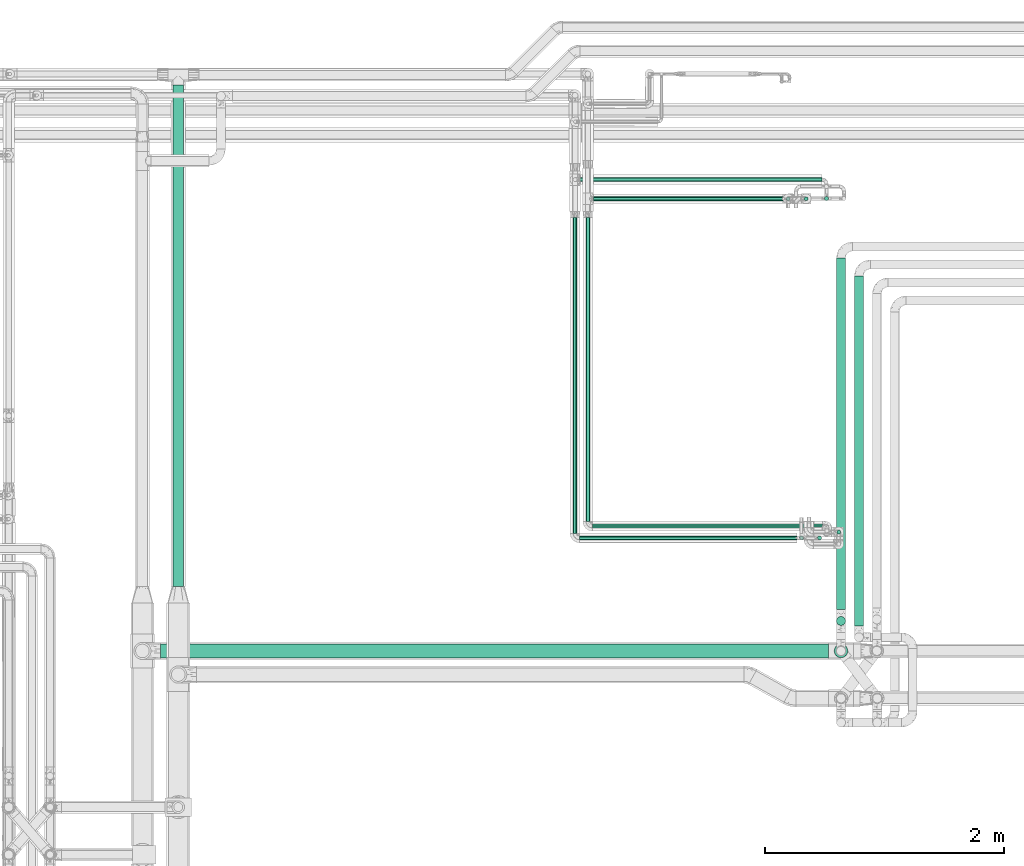
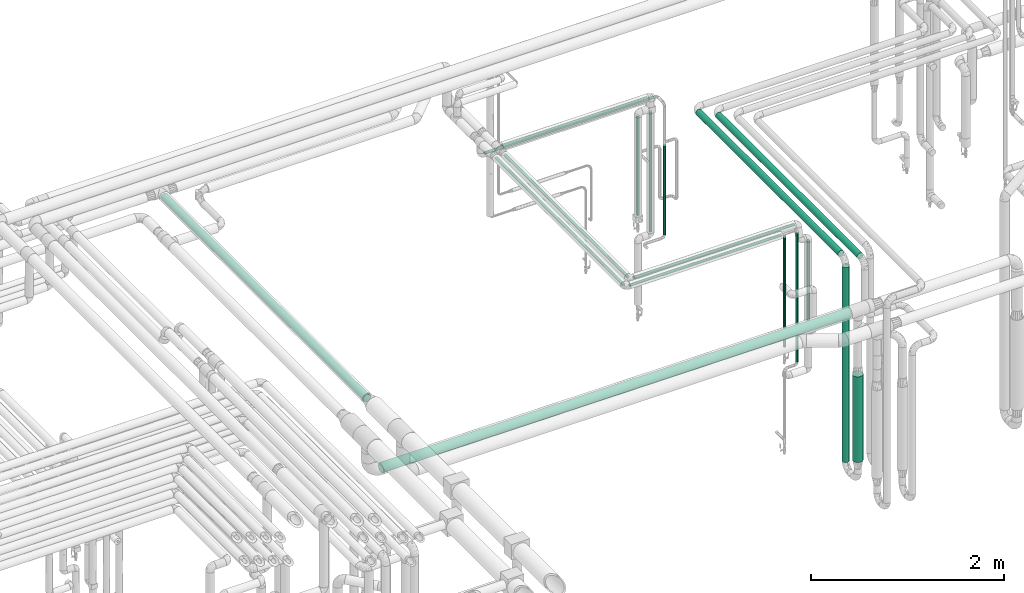
# One storey, part 535 of 827: 18 flow segments.
"""IFC2X3 building model written with IfcOpenShell, lengths in millimetres."""

import ifcopenshell
import ifcopenshell.guid

model = None  # the IFC model being written
_history = None  # IfcOwnerHistory: only IFC2X3 demands one
_inside = {}  # id of a spatial element -> (the spatial element, [elements in it])
_under = {}  # id of a project, library or spatial element -> (it, [spatial elements below it])
_declared = {}  # id of a project -> (the project, [libraries it declares])
_typed = {}  # id of a type object -> (the type object, [elements of that type])
_made_of = {}  # id of a material, layer set ... -> (it, [elements and type objects made of it])


def new_model(schema):
    """Start an empty IFC model of exactly this schema.

    Asked for "IFC4X3", IfcOpenShell would pick the latest addendum, in which some entities
    have other attributes; the version numbers below select the first issue.
    IFC2X3 requires an IfcOwnerHistory on every rooted entity: one is made here for all.
    """
    global model, _history
    if schema == "IFC4X3":
        model = ifcopenshell.file(schema_version=(4, 3, 0, 0))
    else:
        model = ifcopenshell.file(schema=schema)
    _inside.clear()
    _under.clear()
    _declared.clear()
    _typed.clear()
    _made_of.clear()
    _history = None
    if model.schema == "IFC2X3":
        org = make("IfcOrganization", Name="unknown")
        user = make(
            "IfcPersonAndOrganization",
            ThePerson=make("IfcPerson", FamilyName="unknown"),
            TheOrganization=org,
        )
        app = make(
            "IfcApplication",
            ApplicationDeveloper=org,
            Version="unknown",
            ApplicationFullName="unknown",
            ApplicationIdentifier="unknown",
        )
        _history = make(
            "IfcOwnerHistory",
            OwningUser=user,
            OwningApplication=app,
            ChangeAction="ADDED",
            CreationDate=0,
        )
    return model


def make(cls, **values):
    """One entity of the class cls with the attributes given. An attribute that is None is left unset."""
    return model.create_entity(
        cls, **{name: value for name, value in values.items() if value is not None}
    )


def entity(cls, *values):
    """Any entity or typed value of the class cls, its attributes in the order of the schema. None: left unset."""
    e = model.create_entity(cls)
    for i, value in enumerate(values):
        if value is not None:
            e[i] = value
    return e


def rooted(cls, **values):
    """An entity with a GlobalId (a new one), such as an element, a storey or a relation."""
    return make(cls, GlobalId=ifcopenshell.guid.new(), OwnerHistory=_history, **values)


def si_unit(unit_type, name, prefix=None):
    """IfcSIUnit, for example si_unit("LENGTHUNIT", "METRE", prefix="MILLI")."""
    return make("IfcSIUnit", UnitType=unit_type, Prefix=prefix, Name=name)


def converted_unit(unit_type, name, factor, base, dimensions=None, offset=None):
    """IfcConversionBasedUnit, such as the inch: factor (a typed value) times the base unit."""
    return make(
        "IfcConversionBasedUnit"
        if offset is None
        else "IfcConversionBasedUnitWithOffset",
        ConversionOffset=offset,
        Dimensions=None
        if dimensions is None
        else entity("IfcDimensionalExponents", *dimensions),
        UnitType=unit_type,
        Name=name,
        ConversionFactor=make(
            "IfcMeasureWithUnit", ValueComponent=factor, UnitComponent=base
        ),
    )


def derived_unit(unit_type, elements):
    """IfcDerivedUnit: a product of units, each with its exponent."""
    return make(
        "IfcDerivedUnit",
        Elements=[
            make("IfcDerivedUnitElement", Unit=unit, Exponent=power)
            for unit, power in elements
        ],
        UnitType=unit_type,
    )


def assignment(units):
    """IfcUnitAssignment: the units of a project."""
    return None if units is None else make("IfcUnitAssignment", Units=units)


def point(xyz):
    """IfcCartesianPoint."""
    return None if xyz is None else make("IfcCartesianPoint", Coordinates=xyz)


def direction(xyz):
    """IfcDirection."""
    return None if xyz is None else make("IfcDirection", DirectionRatios=xyz)


def frame(location, z_axis=None, x_axis=None):
    """IfcAxis2Placement3D, a coordinate frame: its origin and axes. An axis left out is left unset."""
    return make(
        "IfcAxis2Placement3D",
        Location=point(location),
        Axis=direction(z_axis),
        RefDirection=direction(x_axis),
    )


def frame_2d(location, x_axis=None):
    """IfcAxis2Placement2D, a coordinate frame in the plane: its origin and x axis."""
    return make(
        "IfcAxis2Placement2D", Location=point(location), RefDirection=direction(x_axis)
    )


def origin():
    """The frame at (0, 0, 0) with its axes left unset."""
    return frame((0.0, 0.0, 0.0))


def origin_2d_with_axis():
    """The frame at (0, 0) in the plane with the x axis (1, 0) written out."""
    return frame_2d((0.0, 0.0), x_axis=(1.0, 0.0))


def place(relative_to, where):
    """IfcLocalPlacement: puts the frame where relative to a parent placement (None: the world)."""
    return make(
        "IfcLocalPlacement", PlacementRelTo=relative_to, RelativePlacement=where
    )


def context(
    kind, dimensions, precision=None, world=None, true_north=None, identifier=None
):
    """IfcGeometricRepresentationContext, for example the 3D "Model" context."""
    return make(
        "IfcGeometricRepresentationContext",
        ContextIdentifier=identifier,
        ContextType=kind,
        CoordinateSpaceDimension=dimensions,
        Precision=precision,
        WorldCoordinateSystem=world,
        TrueNorth=true_north,
    )


def subcontext(parent, identifier, kind, view, scale=None):
    """IfcGeometricRepresentationSubContext, for example "Body" below "Model"."""
    return make(
        "IfcGeometricRepresentationSubContext",
        ContextIdentifier=identifier,
        ContextType=kind,
        ParentContext=parent,
        TargetScale=scale,
        TargetView=view,
    )


def project(units=None, contexts=None):
    """IfcProject with its units and contexts."""
    return rooted(
        "IfcProject",
        Name="project",
        RepresentationContexts=contexts,
        UnitsInContext=assignment(units),
    )


def spatial(cls, under=None, at=None, **own):
    """A site, building, storey or space (cls), placed at a placement, below another one or the project."""
    s = rooted(cls, ObjectPlacement=at, **own)
    if under is not None:
        _under.setdefault(under.id(), (under, []))[1].append(s)
    return s


def profile(cls, at=None, kind="AREA", **sizes):
    """A parametric profile (cls). Its sizes go by their IFC names, for example OverallWidth=200.0."""
    return make(cls, ProfileType=kind, Position=at, **sizes)


def circle(**sizes):
    """IfcCircleProfileDef."""
    return profile("IfcCircleProfileDef", **sizes)


def extrude(swept, where, along, depth):
    """IfcExtrudedAreaSolid: the profile swept, set in the frame where, extruded along a direction by depth."""
    return make(
        "IfcExtrudedAreaSolid",
        SweptArea=swept,
        Position=where,
        ExtrudedDirection=direction(along),
        Depth=depth,
    )


def shape(context_of_items, identifier, shape_type, items):
    """IfcShapeRepresentation: the items that make up one representation, for example the "Body"."""
    return make(
        "IfcShapeRepresentation",
        ContextOfItems=context_of_items,
        RepresentationIdentifier=identifier,
        RepresentationType=shape_type,
        Items=items,
    )


def made_of(thing, what):
    """Note that an element or type object is made of a material, layer set ...; save() writes the relation."""
    if what is not None:
        _made_of.setdefault(what.id(), (what, []))[1].append(thing)
    return thing


def type_object(cls, material=None, **own):
    """A type object (cls), such as IfcWallType, which elements share."""
    return made_of(rooted(cls, **own), material)


def element(
    cls,
    number,
    at=None,
    inside=None,
    cuts=None,
    type_object=None,
    material=None,
    context=None,
    identifier="Body",
    shape_type=None,
    held_by="IfcProductDefinitionShape",
    body=None,
    shapes=None,
    **own,
):
    """One element of the class cls, such as IfcWall. Its Tag is "e" and its number.

    at: its placement. inside: the storey or other place that contains it. cuts: it is an
    opening in that element (IfcRelVoidsElement). A single representation is given by context,
    identifier, shape_type and body (its items); several are given by shapes. held_by: the class
    of the entity that holds the representations. save() writes the other relations.
    """
    e = rooted(cls, Tag="e%d" % number, ObjectPlacement=at, **own)
    if body is not None:
        shapes = [shape(context, identifier, shape_type, body)]
    if shapes is not None:
        e.Representation = make(held_by, Representations=shapes)
    if inside is not None:
        _inside.setdefault(inside.id(), (inside, []))[1].append(e)
    if cuts is not None:
        rooted(
            "IfcRelVoidsElement", RelatingBuildingElement=cuts, RelatedOpeningElement=e
        )
    if type_object is not None:
        _typed.setdefault(type_object.id(), (type_object, []))[1].append(e)
    return made_of(e, material)


def aggregate(whole, parts):
    """IfcRelAggregates: a whole, such as a stair, and the parts it consists of."""
    return rooted("IfcRelAggregates", RelatingObject=whole, RelatedObjects=parts)


def save(model, path):
    """Write the relations noted so far, then the file.

    IfcRelAggregates (storeys below a building ...), IfcRelContainedInSpatialStructure (elements
    in a storey), IfcRelDefinesByType, IfcRelAssociatesMaterial and IfcRelDeclares: one each for
    every whole, place, type object, material and project.
    """
    for whole, parts in _under.values():
        aggregate(whole, parts)
    for where, things in _inside.values():
        rooted(
            "IfcRelContainedInSpatialStructure",
            RelatedElements=things,
            RelatingStructure=where,
        )
    for kind, things in _typed.values():
        rooted("IfcRelDefinesByType", RelatedObjects=things, RelatingType=kind)
    for what, things in _made_of.values():
        rooted("IfcRelAssociatesMaterial", RelatedObjects=things, RelatingMaterial=what)
    for by, libraries in _declared.values():
        rooted("IfcRelDeclares", RelatingContext=by, RelatedDefinitions=libraries)
    model.write(path)


model = new_model("IFC2X3")

# Units and contexts
model_context = context("Model", 3, precision=0.01, world=origin(), true_north=direction((6.12303176911189e-17, 1.0)))
body_context = subcontext(model_context, "Body", "Model", "MODEL_VIEW")
ifc_project = project(units=[si_unit("LENGTHUNIT", "METRE", prefix="MILLI"), si_unit("AREAUNIT", "SQUARE_METRE"), si_unit("VOLUMEUNIT", "CUBIC_METRE"), converted_unit("PLANEANGLEUNIT", "DEGREE", entity("IfcRatioMeasure", 0.0174532925199433), si_unit("PLANEANGLEUNIT", "RADIAN"), dimensions=[0, 0, 0, 0, 0, 0, 0]), si_unit("MASSUNIT", "GRAM", prefix="KILO"), derived_unit("MASSDENSITYUNIT", [(si_unit("MASSUNIT", "GRAM", prefix="KILO"), 1), (si_unit("LENGTHUNIT", "METRE"), -3)]), derived_unit("MOMENTOFINERTIAUNIT", [(si_unit("LENGTHUNIT", "METRE"), 4)]), si_unit("TIMEUNIT", "SECOND"), si_unit("FREQUENCYUNIT", "HERTZ"), si_unit("THERMODYNAMICTEMPERATUREUNIT", "DEGREE_CELSIUS"), derived_unit("THERMALTRANSMITTANCEUNIT", [(si_unit("MASSUNIT", "GRAM", prefix="KILO"), 1), (si_unit("THERMODYNAMICTEMPERATUREUNIT", "KELVIN"), -1), (si_unit("TIMEUNIT", "SECOND"), -3)]), derived_unit("VOLUMETRICFLOWRATEUNIT", [(si_unit("LENGTHUNIT", "METRE"), 3), (si_unit("TIMEUNIT", "SECOND"), -1)]), derived_unit("MASSFLOWRATEUNIT", [(si_unit("MASSUNIT", "GRAM", prefix="KILO"), 1), (si_unit("TIMEUNIT", "SECOND"), -1)]), derived_unit("ROTATIONALFREQUENCYUNIT", [(si_unit("TIMEUNIT", "SECOND"), -1)]), si_unit("ELECTRICCURRENTUNIT", "AMPERE"), si_unit("ELECTRICVOLTAGEUNIT", "VOLT"), si_unit("POWERUNIT", "WATT"), si_unit("FORCEUNIT", "NEWTON", prefix="KILO"), si_unit("ILLUMINANCEUNIT", "LUX"), si_unit("LUMINOUSFLUXUNIT", "LUMEN"), si_unit("LUMINOUSINTENSITYUNIT", "CANDELA"), derived_unit("USERDEFINED", [(si_unit("MASSUNIT", "GRAM", prefix="KILO"), -1), (si_unit("LENGTHUNIT", "METRE"), -2), (si_unit("TIMEUNIT", "SECOND"), 3), (si_unit("LUMINOUSFLUXUNIT", "LUMEN"), 1)]), derived_unit("LINEARVELOCITYUNIT", [(si_unit("LENGTHUNIT", "METRE"), 1), (si_unit("TIMEUNIT", "SECOND"), -1)]), si_unit("PRESSUREUNIT", "PASCAL"), derived_unit("USERDEFINED", [(si_unit("LENGTHUNIT", "METRE"), -2), (si_unit("MASSUNIT", "GRAM", prefix="KILO"), 1), (si_unit("TIMEUNIT", "SECOND"), -2)]), derived_unit("LINEARFORCEUNIT", [(si_unit("MASSUNIT", "GRAM", prefix="KILO"), 1), (si_unit("LENGTHUNIT", "METRE"), 1), (si_unit("TIMEUNIT", "SECOND"), -2), (si_unit("LENGTHUNIT", "METRE"), -1)]), derived_unit("PLANARFORCEUNIT", [(si_unit("MASSUNIT", "GRAM", prefix="KILO"), 1), (si_unit("LENGTHUNIT", "METRE"), 1), (si_unit("TIMEUNIT", "SECOND"), -2), (si_unit("LENGTHUNIT", "METRE"), -2)])], contexts=[model_context])

# Site, building, storey
site_placement = place(None, origin())
site = spatial("IfcSite", under=ifc_project, at=site_placement, CompositionType="ELEMENT")
building_placement = place(site_placement, origin())
building = spatial("IfcBuilding", under=site, at=building_placement, CompositionType="ELEMENT")
storey_placement = place(building_placement, frame((0.0, 0.0, 28200.0)))
storey = spatial("IfcBuildingStorey", under=building, at=storey_placement, Name="08", CompositionType="ELEMENT", Elevation=28200.0)

# Flow segments
pipe_segment_type_1 = type_object("IfcPipeSegmentType", PredefinedType="NOTDEFINED")
flow_segment_1_placement = place(storey_placement, frame((38002.2, 14827.72, 2953.9)))
element("IfcFlowSegment", 1, at=flow_segment_1_placement, inside=storey, type_object=pipe_segment_type_1, context=body_context, shape_type="SweptSolid", body=[
    extrude(circle(Radius=44.5, at=origin_2d_with_axis()), frame((46.1, 0.0, 46.1), z_axis=(0.0, 1.0, 0.0), x_axis=(-1.0, 0.0, 0.0)), (0.0, 0.0, 1.0), 4193.99999999999),
])
pipe_segment_type_2 = type_object("IfcPipeSegmentType", PredefinedType="NOTDEFINED")
flow_segment_2_placement = place(storey_placement, frame((37900.3, 14228.02, 2441.4)))
element("IfcFlowSegment", 2, at=flow_segment_2_placement, inside=storey, type_object=pipe_segment_type_2, context=body_context, shape_type="SweptSolid", body=[
    extrude(circle(Radius=57.0, at=origin_2d_with_axis()), frame((0.0, 58.6, 58.6), z_axis=(1.0, 0.0, 0.0), x_axis=(0.0, 1.0, 0.0)), (0.0, 0.0, 1.0), 5589.73431158422),
])
flow_segment_3_placement = place(storey_placement, frame((43555.69, 14498.73, 445.0)))
element("IfcFlowSegment", 3, at=flow_segment_3_placement, inside=storey, type_object=pipe_segment_type_2, context=body_context, shape_type="SweptSolid", body=[
    extrude(circle(Radius=37.75, at=origin_2d_with_axis()), frame((39.35, 39.35, 0.0), z_axis=(0.0, 0.0, 1.0), x_axis=(-1.0, 0.0, 0.0)), (0.0, 0.0, 1.0), 2460.0),
])
flow_segment_4_placement = place(storey_placement, frame((43705.69, 14496.04, 2960.65)))
element("IfcFlowSegment", 4, at=flow_segment_4_placement, inside=storey, type_object=pipe_segment_type_2, context=body_context, shape_type="SweptSolid", body=[
    extrude(circle(Radius=37.75, at=origin_2d_with_axis()), frame((39.35, 0.0, 39.35), z_axis=(0.0, 1.0, 0.0), x_axis=(1.0, 0.0, 0.0)), (0.0, 0.0, 1.0), 2930.00000000002),
])
flow_segment_5_placement = place(storey_placement, frame((43555.69, 14633.08, 2960.65)))
element("IfcFlowSegment", 5, at=flow_segment_5_placement, inside=storey, type_object=pipe_segment_type_2, context=body_context, shape_type="SweptSolid", body=[
    extrude(circle(Radius=37.75, at=origin_2d_with_axis()), frame((39.35, 0.0, 39.35), z_axis=(0.0, 1.0, 0.0), x_axis=(1.0, 0.0, 0.0)), (0.0, 0.0, 1.0), 2943.15846247455),
])
flow_segment_6_placement = place(storey_placement, frame((41524.22, 18052.89, 2981.65)))
element("IfcFlowSegment", 6, at=flow_segment_6_placement, inside=storey, type_object=pipe_segment_type_2, context=body_context, shape_type="SweptSolid", body=[
    extrude(circle(Radius=16.75, at=origin_2d_with_axis()), frame((0.0, 18.35, 18.35), z_axis=(1.0, 0.0, 0.0), x_axis=(0.0, 1.0, 0.0)), (0.0, 0.0, 1.0), 1740.87191154267),
])
flow_segment_7_placement = place(storey_placement, frame((43284.74, 18052.89, 1297.88)))
element("IfcFlowSegment", 7, at=flow_segment_7_placement, inside=storey, type_object=pipe_segment_type_2, context=body_context, shape_type="SweptSolid", body=[
    extrude(circle(Radius=16.75, at=origin_2d_with_axis()), frame((18.35, 18.35, 0.0)), (0.0, 0.0, 1.0), 1514.12352106977),
])
flow_segment_8_placement = place(storey_placement, frame((43454.74, 18055.09, 1199.75)))
element("IfcFlowSegment", 8, at=flow_segment_8_placement, inside=storey, type_object=pipe_segment_type_2, context=body_context, shape_type="SweptSolid", body=[
    extrude(circle(Radius=16.75, at=origin_2d_with_axis()), frame((18.35, 18.35, 0.0)), (0.0, 0.0, 1.0), 1126.13619417941),
])
flow_segment_9_placement = place(storey_placement, frame((41407.37, 18212.59, 2831.65)))
element("IfcFlowSegment", 9, at=flow_segment_9_placement, inside=storey, type_object=pipe_segment_type_2, context=body_context, shape_type="SweptSolid", body=[
    extrude(circle(Radius=16.75, at=origin_2d_with_axis()), frame((0.0, 18.35, 18.35), z_axis=(1.0, 0.0, 0.0), x_axis=(0.0, -1.0, 0.0)), (0.0, 0.0, 1.0), 2027.71557427449),
])
flow_segment_10_placement = place(storey_placement, frame((43134.74, 18052.59, 1557.25)))
element("IfcFlowSegment", 10, at=flow_segment_10_placement, inside=storey, type_object=pipe_segment_type_2, context=body_context, shape_type="SweptSolid", body=[
    extrude(circle(Radius=16.75, at=origin_2d_with_axis()), frame((18.35, 18.35, 0.0)), (0.0, 0.0, 1.0), 1254.75207132545),
])
flow_segment_11_placement = place(storey_placement, frame((41457.87, 15370.31, 2981.65)))
element("IfcFlowSegment", 11, at=flow_segment_11_placement, inside=storey, type_object=pipe_segment_type_2, context=body_context, shape_type="SweptSolid", body=[
    extrude(circle(Radius=16.75, at=origin_2d_with_axis()), frame((18.35, 0.0, 18.35), z_axis=(0.0, 1.0, 0.0), x_axis=(-1.0, 0.0, 0.0)), (0.0, 0.0, 1.0), 2542.92701824606),
])
flow_segment_12_placement = place(storey_placement, frame((41514.22, 15313.97, 2981.65)))
element("IfcFlowSegment", 12, at=flow_segment_12_placement, inside=storey, type_object=pipe_segment_type_2, context=body_context, shape_type="SweptSolid", body=[
    extrude(circle(Radius=16.75, at=origin_2d_with_axis()), frame((0.0, 18.35, 18.35), z_axis=(1.0, 0.0, 0.0), x_axis=(0.0, -1.0, 0.0)), (0.0, 0.0, 1.0), 1924.0),
])
flow_segment_13_placement = place(storey_placement, frame((43557.87, 15262.98, 1737.28)))
element("IfcFlowSegment", 13, at=flow_segment_13_placement, inside=storey, type_object=pipe_segment_type_2, context=body_context, shape_type="SweptSolid", body=[
    extrude(circle(Radius=16.75, at=origin_2d_with_axis()), frame((18.35, 18.35, 0.0), z_axis=(0.0, 0.0, 1.0), x_axis=(-1.0, 0.0, 0.0)), (0.0, 0.0, 1.0), 1046.92285172848),
])
flow_segment_14_placement = place(storey_placement, frame((41351.03, 15270.84, 2981.65)))
element("IfcFlowSegment", 14, at=flow_segment_14_placement, inside=storey, type_object=pipe_segment_type_2, context=body_context, shape_type="SweptSolid", body=[
    extrude(circle(Radius=16.75, at=origin_2d_with_axis()), frame((18.35, 0.0, 18.35), z_axis=(0.0, 1.0, 0.0), x_axis=(1.0, 0.0, 0.0)), (0.0, 0.0, 1.0), 2643.69565792124),
])
flow_segment_15_placement = place(storey_placement, frame((43397.28, 15214.49, 1338.01)))
element("IfcFlowSegment", 15, at=flow_segment_15_placement, inside=storey, type_object=pipe_segment_type_2, context=body_context, shape_type="SweptSolid", body=[
    extrude(circle(Radius=16.75, at=origin_2d_with_axis()), frame((18.35, 18.35, 0.0)), (0.0, 0.0, 1.0), 1623.9879679537),
])
flow_segment_16_placement = place(storey_placement, frame((41407.37, 15214.49, 2981.65)))
element("IfcFlowSegment", 16, at=flow_segment_16_placement, inside=storey, type_object=pipe_segment_type_2, context=body_context, shape_type="SweptSolid", body=[
    extrude(circle(Radius=16.75, at=origin_2d_with_axis()), frame((0.0, 18.35, 18.35), z_axis=(1.0, 0.0, 0.0), x_axis=(0.0, -1.0, 0.0)), (0.0, 0.0, 1.0), 1819.69971348912),
])
flow_segment_17_placement = place(storey_placement, frame((43246.73, 15214.49, 1577.96)))
element("IfcFlowSegment", 17, at=flow_segment_17_placement, inside=storey, type_object=pipe_segment_type_2, context=body_context, shape_type="SweptSolid", body=[
    extrude(circle(Radius=16.75, at=origin_2d_with_axis()), frame((18.35, 18.35, 0.0)), (0.0, 0.0, 1.0), 1384.03796795371),
])
flow_segment_18_placement = place(storey_placement, frame((43536.44, 14228.02, 612.0)))
element("IfcFlowSegment", 18, at=flow_segment_18_placement, inside=storey, type_object=pipe_segment_type_2, context=body_context, shape_type="SweptSolid", body=[
    extrude(circle(Radius=57.0, at=origin_2d_with_axis()), frame((58.6, 58.6, 0.0)), (0.0, 0.0, 1.0), 1081.19999999998),
])

save(model, "model.ifc")
